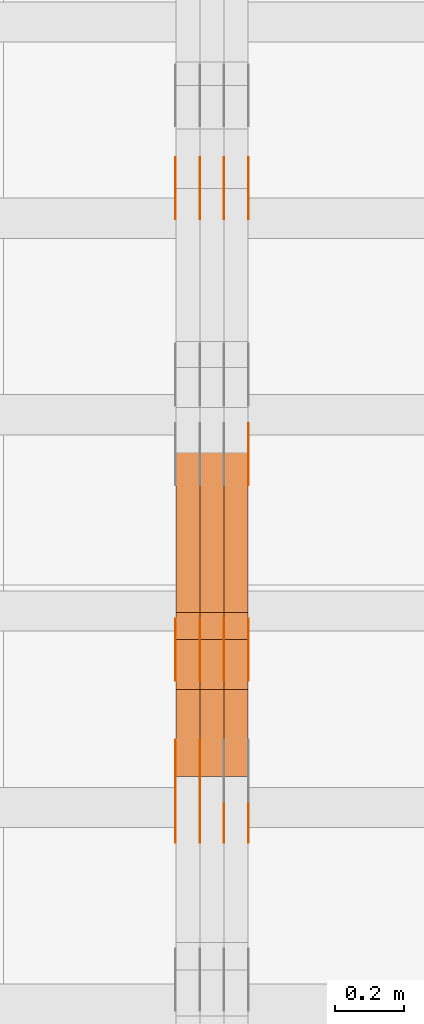
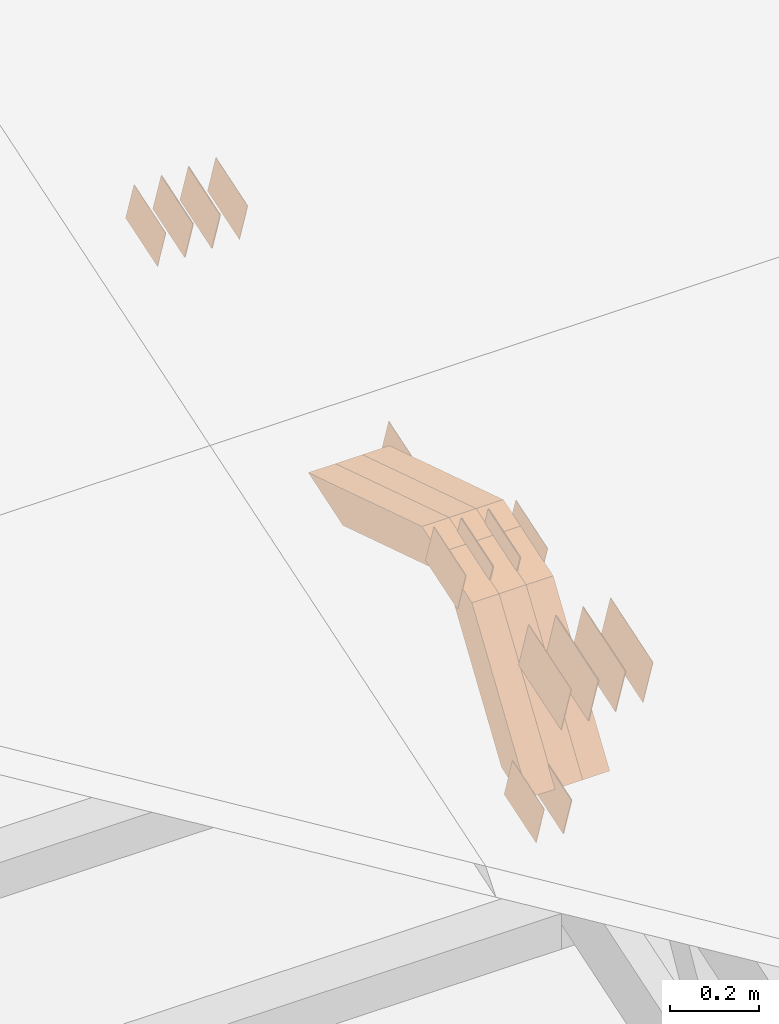
# One storey, part 113 of 385: 28 proxies.
"""IFC2X3 building model written with IfcOpenShell, lengths in millimetres."""

from ifc_helpers import new_model, entity, si_unit, converted_unit, derived_unit, direction, frame, origin, place, context, subcontext, project, spatial, polyline, outline, extrude, source, transform, mapped, material, type_object, type_shapes, element, save


model = new_model("IFC2X3")

# Units and contexts
model_context = context("Model", 3, precision=0.01, world=origin(), true_north=direction((6.12303176911189e-17, 1.0)))
body_context = subcontext(model_context, "Body", "Model", "MODEL_VIEW")
ifc_project = project(units=[si_unit("LENGTHUNIT", "METRE", prefix="MILLI"), si_unit("AREAUNIT", "SQUARE_METRE"), si_unit("VOLUMEUNIT", "CUBIC_METRE"), converted_unit("PLANEANGLEUNIT", "DEGREE", entity("IfcRatioMeasure", 0.0174532925199433), si_unit("PLANEANGLEUNIT", "RADIAN"), dimensions=[0, 0, 0, 0, 0, 0, 0]), si_unit("MASSUNIT", "GRAM", prefix="KILO"), derived_unit("MASSDENSITYUNIT", [(si_unit("MASSUNIT", "GRAM", prefix="KILO"), 1), (si_unit("LENGTHUNIT", "METRE"), -3)]), si_unit("TIMEUNIT", "SECOND"), si_unit("FREQUENCYUNIT", "HERTZ"), si_unit("THERMODYNAMICTEMPERATUREUNIT", "DEGREE_CELSIUS"), derived_unit("THERMALTRANSMITTANCEUNIT", [(si_unit("MASSUNIT", "GRAM", prefix="KILO"), 1), (si_unit("THERMODYNAMICTEMPERATUREUNIT", "KELVIN"), -1), (si_unit("TIMEUNIT", "SECOND"), -3)]), derived_unit("VOLUMETRICFLOWRATEUNIT", [(si_unit("LENGTHUNIT", "METRE"), 3), (si_unit("TIMEUNIT", "SECOND"), -1)]), si_unit("ELECTRICCURRENTUNIT", "AMPERE"), si_unit("ELECTRICVOLTAGEUNIT", "VOLT"), si_unit("POWERUNIT", "WATT"), si_unit("FORCEUNIT", "NEWTON", prefix="KILO"), si_unit("ILLUMINANCEUNIT", "LUX"), si_unit("LUMINOUSFLUXUNIT", "LUMEN"), si_unit("LUMINOUSINTENSITYUNIT", "CANDELA"), derived_unit("USERDEFINED", [(si_unit("MASSUNIT", "GRAM", prefix="KILO"), -1), (si_unit("LENGTHUNIT", "METRE"), -2), (si_unit("TIMEUNIT", "SECOND"), 3), (si_unit("LUMINOUSFLUXUNIT", "LUMEN"), 1)]), derived_unit("LINEARVELOCITYUNIT", [(si_unit("LENGTHUNIT", "METRE"), 1), (si_unit("TIMEUNIT", "SECOND"), -1)]), si_unit("PRESSUREUNIT", "PASCAL"), derived_unit("USERDEFINED", [(si_unit("LENGTHUNIT", "METRE"), -2), (si_unit("MASSUNIT", "GRAM", prefix="KILO"), 1), (si_unit("TIMEUNIT", "SECOND"), -2)])], contexts=[model_context])

# Site, building, storey
site_placement = place(None, origin())
site = spatial("IfcSite", under=ifc_project, at=site_placement, CompositionType="ELEMENT")
building_placement = place(site_placement, origin())
building = spatial("IfcBuilding", under=site, at=building_placement, CompositionType="ELEMENT")
storey_placement = place(building_placement, origin())
storey = spatial("IfcBuildingStorey", under=building, at=storey_placement, Name="Default", CompositionType="ELEMENT", Elevation=0.0)

# Proxies
ifc_material_1 = material(Name="IfcSurfaceStyle #276294")
building_element_proxy_type_1 = type_object("IfcBuildingElementProxyType", PredefinedType="NOTDEFINED", material=ifc_material_1)
shared_shape_1 = source(origin(), body_context, "Body", "SweptSolid", [
    extrude(outline(polyline([(-74.9998754286198, -60.0000016373433), (74.9998605591145, -60.0000016373433), (74.999875428618, 60.0000016373433), (-74.9998605591127, 60.0000016373433), (-74.9998754286198, -60.0000016373433)])), frame((75.0007059026038, 60.000210935219, 0.0), z_axis=(0.0, 0.0, 1.0), x_axis=(-1.0, 0.0, 0.0)), (0.0, 0.0, 1.0), 1.3),
])
type_shapes(building_element_proxy_type_1, [shared_shape_1])
proxy_1_placement = place(building_placement, frame((21386.3, 6760.15341914203, 1372.60670336718), z_axis=(-1.0, 0.0, 0.0), x_axis=(0.0, 0.951056516295124, 0.309016994375039)))
element("IfcBuildingElementProxy", 1, at=proxy_1_placement, inside=storey, type_object=building_element_proxy_type_1, material=ifc_material_1, context=body_context, shape_type="MappedRepresentation", body=[
    mapped(shared_shape_1, transform((0.0, 0.0, 0.0), scale=1.0)),
])
ifc_material_2 = material(Name="IfcSurfaceStyle #276237")
building_element_proxy_type_2 = type_object("IfcBuildingElementProxyType", PredefinedType="NOTDEFINED", material=ifc_material_2)
shared_shape_2 = source(origin(), body_context, "Body", "SweptSolid", [
    extrude(outline(polyline([(-74.9998754286198, -60.0000016373433), (74.9998605591145, -60.0000016373433), (74.999875428618, 60.0000016373433), (-74.9998605591127, 60.0000016373433), (-74.9998754286198, -60.0000016373433)])), frame((75.0007059026038, 60.000210935219, 0.0), z_axis=(0.0, 0.0, 1.0), x_axis=(-1.0, 0.0, 0.0)), (0.0, 0.0, 1.0), 1.3),
])
type_shapes(building_element_proxy_type_2, [shared_shape_2])
proxy_2_placement = place(building_placement, frame((21315.0, 6760.15341914203, 1372.60670336718), z_axis=(-1.0, 0.0, 0.0), x_axis=(0.0, 0.951056516295124, 0.309016994375039)))
element("IfcBuildingElementProxy", 2, at=proxy_2_placement, inside=storey, type_object=building_element_proxy_type_2, material=ifc_material_2, context=body_context, shape_type="MappedRepresentation", body=[
    mapped(shared_shape_2, transform((0.0, 0.0, 0.0), scale=1.0)),
])
ifc_material_3 = material(Name="IfcSurfaceStyle #276180")
building_element_proxy_type_3 = type_object("IfcBuildingElementProxyType", PredefinedType="NOTDEFINED", material=ifc_material_3)
shared_shape_3 = source(origin(), body_context, "Body", "SweptSolid", [
    extrude(outline(polyline([(-74.9998754286198, -60.0000016373433), (74.9998605591145, -60.0000016373433), (74.999875428618, 60.0000016373433), (-74.9998605591127, 60.0000016373433), (-74.9998754286198, -60.0000016373433)])), frame((75.0007059026038, 60.000210935219, 0.0), z_axis=(0.0, 0.0, 1.0), x_axis=(-1.0, 0.0, 0.0)), (0.0, 0.0, 1.0), 1.3),
])
type_shapes(building_element_proxy_type_3, [shared_shape_3])
proxy_3_placement = place(building_placement, frame((21316.3, 6760.15341914203, 1372.60670336718), z_axis=(-1.0, 0.0, 0.0), x_axis=(0.0, 0.951056516295124, 0.309016994375039)))
element("IfcBuildingElementProxy", 3, at=proxy_3_placement, inside=storey, type_object=building_element_proxy_type_3, material=ifc_material_3, context=body_context, shape_type="MappedRepresentation", body=[
    mapped(shared_shape_3, transform((0.0, 0.0, 0.0), scale=1.0)),
])
ifc_material_4 = material(Name="IfcSurfaceStyle #276123")
building_element_proxy_type_4 = type_object("IfcBuildingElementProxyType", PredefinedType="NOTDEFINED", material=ifc_material_4)
shared_shape_4 = source(origin(), body_context, "Body", "SweptSolid", [
    extrude(outline(polyline([(-74.9998754286198, -60.0000016373433), (74.9998605591145, -60.0000016373433), (74.999875428618, 60.0000016373433), (-74.9998605591127, 60.0000016373433), (-74.9998754286198, -60.0000016373433)])), frame((75.0007059026038, 60.000210935219, 0.0), z_axis=(0.0, 0.0, 1.0), x_axis=(-1.0, 0.0, 0.0)), (0.0, 0.0, 1.0), 1.29999999999999),
])
type_shapes(building_element_proxy_type_4, [shared_shape_4])
proxy_4_placement = place(building_placement, frame((21245.0, 6760.15341914203, 1372.60670336718), z_axis=(-1.0, 0.0, 0.0), x_axis=(0.0, 0.951056516295124, 0.309016994375039)))
element("IfcBuildingElementProxy", 4, at=proxy_4_placement, inside=storey, type_object=building_element_proxy_type_4, material=ifc_material_4, context=body_context, shape_type="MappedRepresentation", body=[
    mapped(shared_shape_4, transform((0.0, 0.0, 0.0), scale=1.0)),
])
ifc_material_5 = material(Name="IfcSurfaceStyle #276066")
building_element_proxy_type_5 = type_object("IfcBuildingElementProxyType", PredefinedType="NOTDEFINED", material=ifc_material_5)
shared_shape_5 = source(origin(), body_context, "Body", "SweptSolid", [
    extrude(outline(polyline([(-74.9998754286198, -60.0000016373433), (74.9998605591145, -60.0000016373433), (74.999875428618, 60.0000016373433), (-74.9998605591127, 60.0000016373433), (-74.9998754286198, -60.0000016373433)])), frame((75.0007059026038, 60.000210935219, 0.0), z_axis=(0.0, 0.0, 1.0), x_axis=(-1.0, 0.0, 0.0)), (0.0, 0.0, 1.0), 1.29999999999999),
])
type_shapes(building_element_proxy_type_5, [shared_shape_5])
proxy_5_placement = place(building_placement, frame((21246.3, 6760.15341914203, 1372.60670336718), z_axis=(-1.0, 0.0, 0.0), x_axis=(0.0, 0.951056516295124, 0.309016994375039)))
element("IfcBuildingElementProxy", 5, at=proxy_5_placement, inside=storey, type_object=building_element_proxy_type_5, material=ifc_material_5, context=body_context, shape_type="MappedRepresentation", body=[
    mapped(shared_shape_5, transform((0.0, 0.0, 0.0), scale=1.0)),
])
ifc_material_6 = material(Name="IfcSurfaceStyle #276009")
building_element_proxy_type_6 = type_object("IfcBuildingElementProxyType", PredefinedType="NOTDEFINED", material=ifc_material_6)
shared_shape_6 = source(origin(), body_context, "Body", "SweptSolid", [
    extrude(outline(polyline([(-74.9998754286198, -60.0000016373433), (74.9998605591145, -60.0000016373433), (74.999875428618, 60.0000016373433), (-74.9998605591127, 60.0000016373433), (-74.9998754286198, -60.0000016373433)])), frame((75.0007059026038, 60.000210935219, 0.0), z_axis=(0.0, 0.0, 1.0), x_axis=(-1.0, 0.0, 0.0)), (0.0, 0.0, 1.0), 1.29999999999999),
])
type_shapes(building_element_proxy_type_6, [shared_shape_6])
proxy_6_placement = place(building_placement, frame((21175.0, 6760.15341914203, 1372.60670336718), z_axis=(-1.0, 0.0, 0.0), x_axis=(0.0, 0.951056516295124, 0.309016994375039)))
element("IfcBuildingElementProxy", 6, at=proxy_6_placement, inside=storey, type_object=building_element_proxy_type_6, material=ifc_material_6, context=body_context, shape_type="MappedRepresentation", body=[
    mapped(shared_shape_6, transform((0.0, 0.0, 0.0), scale=1.0)),
])
ifc_material_7 = material(Name="IfcSurfaceStyle #270309")
building_element_proxy_type_7 = type_object("IfcBuildingElementProxyType", PredefinedType="NOTDEFINED", material=ifc_material_7)
shared_shape_7 = source(origin(), body_context, "Body", "SweptSolid", [
    extrude(outline(polyline([(-74.9998707133927, -60.0000596852269), (74.9998841352353, -60.0000596852269), (74.999861282944, 60.0000596852269), (-74.9998747047866, 60.0000596852269), (-74.9998707133927, -60.0000596852269)])), frame((74.9998841352353, 60.0000596852269, 0.0), z_axis=(0.0, 0.0, 1.0), x_axis=(-1.0, 0.0, 0.0)), (0.0, 0.0, 1.0), 1.29999999999999),
])
type_shapes(building_element_proxy_type_7, [shared_shape_7])
proxy_7_placement = place(building_placement, frame((21245.0, 5067.4882362875, 826.131473120182), z_axis=(-1.0, 0.0, 0.0), x_axis=(0.0, 0.951056516295124, 0.309016994375039)))
element("IfcBuildingElementProxy", 7, at=proxy_7_placement, inside=storey, type_object=building_element_proxy_type_7, material=ifc_material_7, context=body_context, shape_type="MappedRepresentation", body=[
    mapped(shared_shape_7, transform((0.0, 0.0, 0.0), scale=1.0)),
])
ifc_material_8 = material(Name="IfcSurfaceStyle #270252")
building_element_proxy_type_8 = type_object("IfcBuildingElementProxyType", PredefinedType="NOTDEFINED", material=ifc_material_8)
shared_shape_8 = source(origin(), body_context, "Body", "SweptSolid", [
    extrude(outline(polyline([(-74.9998707133927, -60.0000596852269), (74.9998841352353, -60.0000596852269), (74.999861282944, 60.0000596852269), (-74.9998747047866, 60.0000596852269), (-74.9998707133927, -60.0000596852269)])), frame((74.9998841352353, 60.0000596852269, 0.0), z_axis=(0.0, 0.0, 1.0), x_axis=(-1.0, 0.0, 0.0)), (0.0, 0.0, 1.0), 1.29999999999999),
])
type_shapes(building_element_proxy_type_8, [shared_shape_8])
proxy_8_placement = place(building_placement, frame((21246.3, 5067.4882362875, 826.131473120182), z_axis=(-1.0, 0.0, 0.0), x_axis=(0.0, 0.951056516295124, 0.309016994375039)))
element("IfcBuildingElementProxy", 8, at=proxy_8_placement, inside=storey, type_object=building_element_proxy_type_8, material=ifc_material_8, context=body_context, shape_type="MappedRepresentation", body=[
    mapped(shared_shape_8, transform((0.0, 0.0, 0.0), scale=1.0)),
])
ifc_material_9 = material(Name="IfcSurfaceStyle #270195")
building_element_proxy_type_9 = type_object("IfcBuildingElementProxyType", PredefinedType="NOTDEFINED", material=ifc_material_9)
shared_shape_9 = source(origin(), body_context, "Body", "SweptSolid", [
    extrude(outline(polyline([(-74.9998707133927, -60.0000596852269), (74.9998841352353, -60.0000596852269), (74.999861282944, 60.0000596852269), (-74.9998747047866, 60.0000596852269), (-74.9998707133927, -60.0000596852269)])), frame((74.9998841352353, 60.0000596852269, 0.0), z_axis=(0.0, 0.0, 1.0), x_axis=(-1.0, 0.0, 0.0)), (0.0, 0.0, 1.0), 1.29999999999999),
])
type_shapes(building_element_proxy_type_9, [shared_shape_9])
proxy_9_placement = place(building_placement, frame((21175.0, 5067.4882362875, 826.131473120182), z_axis=(-1.0, 0.0, 0.0), x_axis=(0.0, 0.951056516295124, 0.309016994375039)))
element("IfcBuildingElementProxy", 9, at=proxy_9_placement, inside=storey, type_object=building_element_proxy_type_9, material=ifc_material_9, context=body_context, shape_type="MappedRepresentation", body=[
    mapped(shared_shape_9, transform((0.0, 0.0, 0.0), scale=1.0)),
])
ifc_material_10 = material(Name="IfcSurfaceStyle #270138")
building_element_proxy_type_10 = type_object("IfcBuildingElementProxyType", PredefinedType="NOTDEFINED", material=ifc_material_10)
shared_shape_10 = source(origin(), body_context, "Body", "SweptSolid", [
    extrude(outline(polyline([(-74.9998801438441, -60.0000306612856), (74.9998747047876, -60.0000306612856), (74.9998707133936, 60.0000306612856), (-74.9998652743371, 60.0000306612856), (-74.9998801438441, -60.0000306612856)])), frame((75.0000206139493, 60.0000306612856, 0.0), z_axis=(0.0, 0.0, 1.0), x_axis=(-1.0, 0.0, 0.0)), (0.0, 0.0, 1.0), 1.3),
])
type_shapes(building_element_proxy_type_10, [shared_shape_10])
proxy_10_placement = place(building_placement, frame((21386.3, 5987.08381858242, 1121.42116774683), z_axis=(-1.0, 0.0, 0.0), x_axis=(0.0, 0.951056516295124, 0.309016994375039)))
element("IfcBuildingElementProxy", 10, at=proxy_10_placement, inside=storey, type_object=building_element_proxy_type_10, material=ifc_material_10, context=body_context, shape_type="MappedRepresentation", body=[
    mapped(shared_shape_10, transform((0.0, 0.0, 0.0), scale=1.0)),
])
ifc_material_11 = material(Name="IfcSurfaceStyle #264666")
building_element_proxy_type_11 = type_object("IfcBuildingElementProxyType", PredefinedType="NOTDEFINED", material=ifc_material_11)
shared_shape_11 = source(origin(), body_context, "Body", "SweptSolid", [
    extrude(outline(polyline([(-74.9998565677224, -60.0000596852342), (74.9998794200083, -60.0000596852342), (74.9998565677242, 60.0000596852342), (-74.9998794200101, 60.0000596852342), (-74.9998565677224, -60.0000596852342)])), frame((74.9998794200083, 60.0000596852342, 0.0), z_axis=(0.0, 0.0, 1.0), x_axis=(-1.0, 0.0, 0.0)), (0.0, 0.0, 1.0), 1.3),
])
type_shapes(building_element_proxy_type_11, [shared_shape_11])
proxy_11_placement = place(building_placement, frame((21386.3, 5418.6991737875, 1250.81341892098), z_axis=(-1.0, 0.0, 0.0), x_axis=(0.0, 0.951056516295154, 0.309016994374948)))
element("IfcBuildingElementProxy", 11, at=proxy_11_placement, inside=storey, type_object=building_element_proxy_type_11, material=ifc_material_11, context=body_context, shape_type="MappedRepresentation", body=[
    mapped(shared_shape_11, transform((0.0, 0.0, 0.0), scale=1.0)),
])
ifc_material_12 = material(Name="IfcSurfaceStyle #264609")
building_element_proxy_type_12 = type_object("IfcBuildingElementProxyType", PredefinedType="NOTDEFINED", material=ifc_material_12)
shared_shape_12 = source(origin(), body_context, "Body", "SweptSolid", [
    extrude(outline(polyline([(-74.9998565677224, -60.0000596852342), (74.9998794200083, -60.0000596852342), (74.9998565677242, 60.0000596852342), (-74.9998794200101, 60.0000596852342), (-74.9998565677224, -60.0000596852342)])), frame((74.9998794200083, 60.0000596852342, 0.0), z_axis=(0.0, 0.0, 1.0), x_axis=(-1.0, 0.0, 0.0)), (0.0, 0.0, 1.0), 1.3),
])
type_shapes(building_element_proxy_type_12, [shared_shape_12])
proxy_12_placement = place(building_placement, frame((21315.0, 5418.6991737875, 1250.81341892098), z_axis=(-1.0, 0.0, 0.0), x_axis=(0.0, 0.951056516295154, 0.309016994374948)))
element("IfcBuildingElementProxy", 12, at=proxy_12_placement, inside=storey, type_object=building_element_proxy_type_12, material=ifc_material_12, context=body_context, shape_type="MappedRepresentation", body=[
    mapped(shared_shape_12, transform((0.0, 0.0, 0.0), scale=1.0)),
])
ifc_material_13 = material(Name="IfcSurfaceStyle #264552")
building_element_proxy_type_13 = type_object("IfcBuildingElementProxyType", PredefinedType="NOTDEFINED", material=ifc_material_13)
shared_shape_13 = source(origin(), body_context, "Body", "SweptSolid", [
    extrude(outline(polyline([(-74.9998565677224, -60.0000596852342), (74.9998794200083, -60.0000596852342), (74.9998565677242, 60.0000596852342), (-74.9998794200101, 60.0000596852342), (-74.9998565677224, -60.0000596852342)])), frame((74.9998794200083, 60.0000596852342, 0.0), z_axis=(0.0, 0.0, 1.0), x_axis=(-1.0, 0.0, 0.0)), (0.0, 0.0, 1.0), 1.3),
])
type_shapes(building_element_proxy_type_13, [shared_shape_13])
proxy_13_placement = place(building_placement, frame((21316.3, 5418.6991737875, 1250.81341892098), z_axis=(-1.0, 0.0, 0.0), x_axis=(0.0, 0.951056516295154, 0.309016994374948)))
element("IfcBuildingElementProxy", 13, at=proxy_13_placement, inside=storey, type_object=building_element_proxy_type_13, material=ifc_material_13, context=body_context, shape_type="MappedRepresentation", body=[
    mapped(shared_shape_13, transform((0.0, 0.0, 0.0), scale=1.0)),
])
ifc_material_14 = material(Name="IfcSurfaceStyle #264495")
building_element_proxy_type_14 = type_object("IfcBuildingElementProxyType", PredefinedType="NOTDEFINED", material=ifc_material_14)
shared_shape_14 = source(origin(), body_context, "Body", "SweptSolid", [
    extrude(outline(polyline([(-74.9998565677224, -60.0000596852342), (74.9998794200083, -60.0000596852342), (74.9998565677242, 60.0000596852342), (-74.9998794200101, 60.0000596852342), (-74.9998565677224, -60.0000596852342)])), frame((74.9998794200083, 60.0000596852342, 0.0), z_axis=(0.0, 0.0, 1.0), x_axis=(-1.0, 0.0, 0.0)), (0.0, 0.0, 1.0), 1.29999999999999),
])
type_shapes(building_element_proxy_type_14, [shared_shape_14])
proxy_14_placement = place(building_placement, frame((21245.0, 5418.6991737875, 1250.81341892098), z_axis=(-1.0, 0.0, 0.0), x_axis=(0.0, 0.951056516295154, 0.309016994374948)))
element("IfcBuildingElementProxy", 14, at=proxy_14_placement, inside=storey, type_object=building_element_proxy_type_14, material=ifc_material_14, context=body_context, shape_type="MappedRepresentation", body=[
    mapped(shared_shape_14, transform((0.0, 0.0, 0.0), scale=1.0)),
])
ifc_material_15 = material(Name="IfcSurfaceStyle #264438")
building_element_proxy_type_15 = type_object("IfcBuildingElementProxyType", PredefinedType="NOTDEFINED", material=ifc_material_15)
shared_shape_15 = source(origin(), body_context, "Body", "SweptSolid", [
    extrude(outline(polyline([(-74.9998565677224, -60.0000596852342), (74.9998794200083, -60.0000596852342), (74.9998565677242, 60.0000596852342), (-74.9998794200101, 60.0000596852342), (-74.9998565677224, -60.0000596852342)])), frame((74.9998794200083, 60.0000596852342, 0.0), z_axis=(0.0, 0.0, 1.0), x_axis=(-1.0, 0.0, 0.0)), (0.0, 0.0, 1.0), 1.29999999999999),
])
type_shapes(building_element_proxy_type_15, [shared_shape_15])
proxy_15_placement = place(building_placement, frame((21246.3, 5418.6991737875, 1250.81341892098), z_axis=(-1.0, 0.0, 0.0), x_axis=(0.0, 0.951056516295154, 0.309016994374948)))
element("IfcBuildingElementProxy", 15, at=proxy_15_placement, inside=storey, type_object=building_element_proxy_type_15, material=ifc_material_15, context=body_context, shape_type="MappedRepresentation", body=[
    mapped(shared_shape_15, transform((0.0, 0.0, 0.0), scale=1.0)),
])
ifc_material_16 = material(Name="IfcSurfaceStyle #264381")
building_element_proxy_type_16 = type_object("IfcBuildingElementProxyType", PredefinedType="NOTDEFINED", material=ifc_material_16)
shared_shape_16 = source(origin(), body_context, "Body", "SweptSolid", [
    extrude(outline(polyline([(-74.9998565677224, -60.0000596852342), (74.9998794200083, -60.0000596852342), (74.9998565677242, 60.0000596852342), (-74.9998794200101, 60.0000596852342), (-74.9998565677224, -60.0000596852342)])), frame((74.9998794200083, 60.0000596852342, 0.0), z_axis=(0.0, 0.0, 1.0), x_axis=(-1.0, 0.0, 0.0)), (0.0, 0.0, 1.0), 1.29999999999999),
])
type_shapes(building_element_proxy_type_16, [shared_shape_16])
proxy_16_placement = place(building_placement, frame((21175.0, 5418.6991737875, 1250.81341892098), z_axis=(-1.0, 0.0, 0.0), x_axis=(0.0, 0.951056516295154, 0.309016994374948)))
element("IfcBuildingElementProxy", 16, at=proxy_16_placement, inside=storey, type_object=building_element_proxy_type_16, material=ifc_material_16, context=body_context, shape_type="MappedRepresentation", body=[
    mapped(shared_shape_16, transform((0.0, 0.0, 0.0), scale=1.0)),
])
ifc_material_17 = material(Name="IfcSurfaceStyle #261246")
building_element_proxy_type_17 = type_object("IfcBuildingElementProxyType", PredefinedType="NOTDEFINED", material=ifc_material_17)
shared_shape_17 = source(origin(), body_context, "Body", "SweptSolid", [
    extrude(outline(polyline([(-99.9996257846169, -71.999973710258), (100.000009625089, -71.999973710258), (99.9996257846187, 71.999973710258), (-100.000009625091, 71.999973710258), (-99.9996257846169, -71.999973710258)])), frame((100.000083496635, 72.0000008245779, 0.0), z_axis=(0.0, 0.0, 1.0), x_axis=(-1.0, 0.0, 0.0)), (0.0, 0.0, 1.0), 1.3),
])
type_shapes(building_element_proxy_type_17, [shared_shape_17])
proxy_17_placement = place(building_placement, frame((21386.3, 4947.73195917316, 1225.53937157357), z_axis=(-1.0, 0.0, 0.0), x_axis=(0.0, 0.951056516295154, 0.309016994374948)))
element("IfcBuildingElementProxy", 17, at=proxy_17_placement, inside=storey, type_object=building_element_proxy_type_17, material=ifc_material_17, context=body_context, shape_type="MappedRepresentation", body=[
    mapped(shared_shape_17, transform((0.0, 0.0, 0.0), scale=1.0)),
])
ifc_material_18 = material(Name="IfcSurfaceStyle #261189")
building_element_proxy_type_18 = type_object("IfcBuildingElementProxyType", PredefinedType="NOTDEFINED", material=ifc_material_18)
shared_shape_18 = source(origin(), body_context, "Body", "SweptSolid", [
    extrude(outline(polyline([(-99.9996257846169, -71.999973710258), (100.000009625089, -71.999973710258), (99.9996257846187, 71.999973710258), (-100.000009625091, 71.999973710258), (-99.9996257846169, -71.999973710258)])), frame((100.000083496635, 72.0000008245779, 0.0), z_axis=(0.0, 0.0, 1.0), x_axis=(-1.0, 0.0, 0.0)), (0.0, 0.0, 1.0), 1.3),
])
type_shapes(building_element_proxy_type_18, [shared_shape_18])
proxy_18_placement = place(building_placement, frame((21315.0, 4947.73195917316, 1225.53937157357), z_axis=(-1.0, 0.0, 0.0), x_axis=(0.0, 0.951056516295154, 0.309016994374948)))
element("IfcBuildingElementProxy", 18, at=proxy_18_placement, inside=storey, type_object=building_element_proxy_type_18, material=ifc_material_18, context=body_context, shape_type="MappedRepresentation", body=[
    mapped(shared_shape_18, transform((0.0, 0.0, 0.0), scale=1.0)),
])
ifc_material_19 = material(Name="IfcSurfaceStyle #261132")
building_element_proxy_type_19 = type_object("IfcBuildingElementProxyType", PredefinedType="NOTDEFINED", material=ifc_material_19)
shared_shape_19 = source(origin(), body_context, "Body", "SweptSolid", [
    extrude(outline(polyline([(-99.9996257846169, -71.999973710258), (100.000009625089, -71.999973710258), (99.9996257846187, 71.999973710258), (-100.000009625091, 71.999973710258), (-99.9996257846169, -71.999973710258)])), frame((100.000083496635, 72.0000008245779, 0.0), z_axis=(0.0, 0.0, 1.0), x_axis=(-1.0, 0.0, 0.0)), (0.0, 0.0, 1.0), 1.3),
])
type_shapes(building_element_proxy_type_19, [shared_shape_19])
proxy_19_placement = place(building_placement, frame((21316.3, 4947.73195917316, 1225.53937157357), z_axis=(-1.0, 0.0, 0.0), x_axis=(0.0, 0.951056516295154, 0.309016994374948)))
element("IfcBuildingElementProxy", 19, at=proxy_19_placement, inside=storey, type_object=building_element_proxy_type_19, material=ifc_material_19, context=body_context, shape_type="MappedRepresentation", body=[
    mapped(shared_shape_19, transform((0.0, 0.0, 0.0), scale=1.0)),
])
ifc_material_20 = material(Name="IfcSurfaceStyle #261075")
building_element_proxy_type_20 = type_object("IfcBuildingElementProxyType", PredefinedType="NOTDEFINED", material=ifc_material_20)
shared_shape_20 = source(origin(), body_context, "Body", "SweptSolid", [
    extrude(outline(polyline([(-99.9996257846169, -71.999973710258), (100.000009625089, -71.999973710258), (99.9996257846187, 71.999973710258), (-100.000009625091, 71.999973710258), (-99.9996257846169, -71.999973710258)])), frame((100.000083496635, 72.0000008245779, 0.0), z_axis=(0.0, 0.0, 1.0), x_axis=(-1.0, 0.0, 0.0)), (0.0, 0.0, 1.0), 1.29999999999998),
])
type_shapes(building_element_proxy_type_20, [shared_shape_20])
proxy_20_placement = place(building_placement, frame((21245.0, 4947.73195917316, 1225.53937157357), z_axis=(-1.0, 0.0, 0.0), x_axis=(0.0, 0.951056516295154, 0.309016994374948)))
element("IfcBuildingElementProxy", 20, at=proxy_20_placement, inside=storey, type_object=building_element_proxy_type_20, material=ifc_material_20, context=body_context, shape_type="MappedRepresentation", body=[
    mapped(shared_shape_20, transform((0.0, 0.0, 0.0), scale=1.0)),
])
ifc_material_21 = material(Name="IfcSurfaceStyle #261018")
building_element_proxy_type_21 = type_object("IfcBuildingElementProxyType", PredefinedType="NOTDEFINED", material=ifc_material_21)
shared_shape_21 = source(origin(), body_context, "Body", "SweptSolid", [
    extrude(outline(polyline([(-99.9996257846169, -71.999973710258), (100.000009625089, -71.999973710258), (99.9996257846187, 71.999973710258), (-100.000009625091, 71.999973710258), (-99.9996257846169, -71.999973710258)])), frame((100.000083496635, 72.0000008245779, 0.0), z_axis=(0.0, 0.0, 1.0), x_axis=(-1.0, 0.0, 0.0)), (0.0, 0.0, 1.0), 1.29999999999998),
])
type_shapes(building_element_proxy_type_21, [shared_shape_21])
proxy_21_placement = place(building_placement, frame((21246.3, 4947.73195917316, 1225.53937157357), z_axis=(-1.0, 0.0, 0.0), x_axis=(0.0, 0.951056516295154, 0.309016994374948)))
element("IfcBuildingElementProxy", 21, at=proxy_21_placement, inside=storey, type_object=building_element_proxy_type_21, material=ifc_material_21, context=body_context, shape_type="MappedRepresentation", body=[
    mapped(shared_shape_21, transform((0.0, 0.0, 0.0), scale=1.0)),
])
ifc_material_22 = material(Name="IfcSurfaceStyle #260961")
building_element_proxy_type_22 = type_object("IfcBuildingElementProxyType", PredefinedType="NOTDEFINED", material=ifc_material_22)
shared_shape_22 = source(origin(), body_context, "Body", "SweptSolid", [
    extrude(outline(polyline([(-99.9996257846169, -71.999973710258), (100.000009625089, -71.999973710258), (99.9996257846187, 71.999973710258), (-100.000009625091, 71.999973710258), (-99.9996257846169, -71.999973710258)])), frame((100.000083496635, 72.0000008245779, 0.0), z_axis=(0.0, 0.0, 1.0), x_axis=(-1.0, 0.0, 0.0)), (0.0, 0.0, 1.0), 1.29999999999999),
])
type_shapes(building_element_proxy_type_22, [shared_shape_22])
proxy_22_placement = place(building_placement, frame((21175.0, 4947.73195917316, 1225.53937157357), z_axis=(-1.0, 0.0, 0.0), x_axis=(0.0, 0.951056516295154, 0.309016994374948)))
element("IfcBuildingElementProxy", 22, at=proxy_22_placement, inside=storey, type_object=building_element_proxy_type_22, material=ifc_material_22, context=body_context, shape_type="MappedRepresentation", body=[
    mapped(shared_shape_22, transform((0.0, 0.0, 0.0), scale=1.0)),
])
ifc_material_23 = material(Name="IfcSurfaceStyle #251904")
building_element_proxy_type_23 = type_object("IfcBuildingElementProxyType", Name="T1-W15 251902", PredefinedType="NOTDEFINED", material=ifc_material_23)
shared_shape_23 = source(origin(), body_context, "Body", "SweptSolid", [
    extrude(outline(polyline([(-243.398341390642, -47.5000170814535), (237.775741169608, -47.5000170814535), (224.054017709933, 0.000127777485579883), (157.692261395711, 47.4999531927108), (-376.12367888461, 47.4999531927107), (-243.398341390642, -47.5000170814535)])), frame((237.77637044506, 47.5003404768297, 0.0), z_axis=(0.0, 0.0, 1.0), x_axis=(-1.0, 0.0, 0.0)), (0.0, 0.0, 1.0), 70.0),
])
type_shapes(building_element_proxy_type_23, [shared_shape_23])
proxy_23_placement = place(building_placement, frame((21385.0, 5540.23242178142, 1288.84274826279), z_axis=(-1.0, 0.0, 0.0), x_axis=(0.0, 0.95322291386448, -0.302268219440466)))
element("IfcBuildingElementProxy", 23, at=proxy_23_placement, inside=storey, type_object=building_element_proxy_type_23, material=ifc_material_23, Name="T1-W15", context=body_context, shape_type="MappedRepresentation", body=[
    mapped(shared_shape_23, transform((0.0, 0.0, 0.0), scale=1.0)),
])
ifc_material_24 = material(Name="IfcSurfaceStyle #251838")
building_element_proxy_type_24 = type_object("IfcBuildingElementProxyType", Name="T1-W15 251836", PredefinedType="NOTDEFINED", material=ifc_material_24)
shared_shape_24 = source(origin(), body_context, "Body", "SweptSolid", [
    extrude(outline(polyline([(-243.398341390642, -47.5000170814535), (237.775741169608, -47.5000170814535), (224.054017709933, 0.000127777485579883), (157.692261395711, 47.4999531927108), (-376.12367888461, 47.4999531927107), (-243.398341390642, -47.5000170814535)])), frame((237.77637044506, 47.5003404768297, 0.0), z_axis=(0.0, 0.0, 1.0), x_axis=(-1.0, 0.0, 0.0)), (0.0, 0.0, 1.0), 70.0),
])
type_shapes(building_element_proxy_type_24, [shared_shape_24])
proxy_24_placement = place(building_placement, frame((21315.0, 5540.23242178142, 1288.84274826279), z_axis=(-1.0, 0.0, 0.0), x_axis=(0.0, 0.95322291386448, -0.302268219440466)))
element("IfcBuildingElementProxy", 24, at=proxy_24_placement, inside=storey, type_object=building_element_proxy_type_24, material=ifc_material_24, Name="T1-W15", context=body_context, shape_type="MappedRepresentation", body=[
    mapped(shared_shape_24, transform((0.0, 0.0, 0.0), scale=1.0)),
])
ifc_material_25 = material(Name="IfcSurfaceStyle #251772")
building_element_proxy_type_25 = type_object("IfcBuildingElementProxyType", Name="T1-W15 251770", PredefinedType="NOTDEFINED", material=ifc_material_25)
shared_shape_25 = source(origin(), body_context, "Body", "SweptSolid", [
    extrude(outline(polyline([(-243.398341390642, -47.5000170814535), (237.775741169608, -47.5000170814535), (224.054017709933, 0.000127777485579883), (157.692261395711, 47.4999531927108), (-376.12367888461, 47.4999531927107), (-243.398341390642, -47.5000170814535)])), frame((237.77637044506, 47.5003404768297, 0.0), z_axis=(0.0, 0.0, 1.0), x_axis=(-1.0, 0.0, 0.0)), (0.0, 0.0, 1.0), 70.0),
])
type_shapes(building_element_proxy_type_25, [shared_shape_25])
proxy_25_placement = place(building_placement, frame((21245.0, 5540.23242178142, 1288.84274826279), z_axis=(-1.0, 0.0, 0.0), x_axis=(0.0, 0.95322291386448, -0.302268219440466)))
element("IfcBuildingElementProxy", 25, at=proxy_25_placement, inside=storey, type_object=building_element_proxy_type_25, material=ifc_material_25, Name="T1-W15", context=body_context, shape_type="MappedRepresentation", body=[
    mapped(shared_shape_25, transform((0.0, 0.0, 0.0), scale=1.0)),
])
ifc_material_26 = material(Name="IfcSurfaceStyle #251508")
building_element_proxy_type_26 = type_object("IfcBuildingElementProxyType", Name="T1-W22 251506", PredefinedType="NOTDEFINED", material=ifc_material_26)
shared_shape_26 = source(origin(), body_context, "Body", "SweptSolid", [
    extrude(outline(polyline([(-351.940486061686, -47.5005995570677), (149.451602529695, -47.5005995570676), (209.614029773051, 0.000108554198836676), (224.491670779786, 47.5010029530092), (-231.616817020846, 47.5000876069273), (-351.940486061686, -47.5005995570677)])), frame((224.491766107217, 47.5005524294596, 0.0), z_axis=(0.0, 0.0, 1.0), x_axis=(-1.0, 2.00686044286885e-06, 0.0)), (0.0, 0.0, 1.0), 70.0),
])
type_shapes(building_element_proxy_type_26, [shared_shape_26])
proxy_26_placement = place(building_placement, frame((21385.0, 5140.03125, 812.615600585936), z_axis=(-1.0, 0.0, 0.0), x_axis=(0.0, 0.554956576676696, 0.831879316970486)))
element("IfcBuildingElementProxy", 26, at=proxy_26_placement, inside=storey, type_object=building_element_proxy_type_26, material=ifc_material_26, Name="T1-W22", context=body_context, shape_type="MappedRepresentation", body=[
    mapped(shared_shape_26, transform((0.0, 0.0, 0.0), scale=1.0)),
])
ifc_material_27 = material(Name="IfcSurfaceStyle #251442")
building_element_proxy_type_27 = type_object("IfcBuildingElementProxyType", Name="T1-W22 251440", PredefinedType="NOTDEFINED", material=ifc_material_27)
shared_shape_27 = source(origin(), body_context, "Body", "SweptSolid", [
    extrude(outline(polyline([(-351.940486061686, -47.5005995570677), (149.451602529695, -47.5005995570676), (209.614029773051, 0.000108554198836676), (224.491670779786, 47.5010029530092), (-231.616817020846, 47.5000876069273), (-351.940486061686, -47.5005995570677)])), frame((224.491766107217, 47.5005524294596, 0.0), z_axis=(0.0, 0.0, 1.0), x_axis=(-1.0, 2.00686044286885e-06, 0.0)), (0.0, 0.0, 1.0), 70.0),
])
type_shapes(building_element_proxy_type_27, [shared_shape_27])
proxy_27_placement = place(building_placement, frame((21315.0, 5140.03125, 812.615600585936), z_axis=(-1.0, 0.0, 0.0), x_axis=(0.0, 0.554956576676696, 0.831879316970486)))
element("IfcBuildingElementProxy", 27, at=proxy_27_placement, inside=storey, type_object=building_element_proxy_type_27, material=ifc_material_27, Name="T1-W22", context=body_context, shape_type="MappedRepresentation", body=[
    mapped(shared_shape_27, transform((0.0, 0.0, 0.0), scale=1.0)),
])
ifc_material_28 = material(Name="IfcSurfaceStyle #251376")
building_element_proxy_type_28 = type_object("IfcBuildingElementProxyType", Name="T1-W22 251374", PredefinedType="NOTDEFINED", material=ifc_material_28)
shared_shape_28 = source(origin(), body_context, "Body", "SweptSolid", [
    extrude(outline(polyline([(-351.940486061686, -47.5005995570677), (149.451602529695, -47.5005995570676), (209.614029773051, 0.000108554198836676), (224.491670779786, 47.5010029530092), (-231.616817020846, 47.5000876069273), (-351.940486061686, -47.5005995570677)])), frame((224.491766107217, 47.5005524294596, 0.0), z_axis=(0.0, 0.0, 1.0), x_axis=(-1.0, 2.00686044286885e-06, 0.0)), (0.0, 0.0, 1.0), 70.0),
])
type_shapes(building_element_proxy_type_28, [shared_shape_28])
proxy_28_placement = place(building_placement, frame((21245.0, 5140.03125, 812.615600585936), z_axis=(-1.0, 0.0, 0.0), x_axis=(0.0, 0.554956576676696, 0.831879316970486)))
element("IfcBuildingElementProxy", 28, at=proxy_28_placement, inside=storey, type_object=building_element_proxy_type_28, material=ifc_material_28, Name="T1-W22", context=body_context, shape_type="MappedRepresentation", body=[
    mapped(shared_shape_28, transform((0.0, 0.0, 0.0), scale=1.0)),
])

save(model, "model.ifc")
